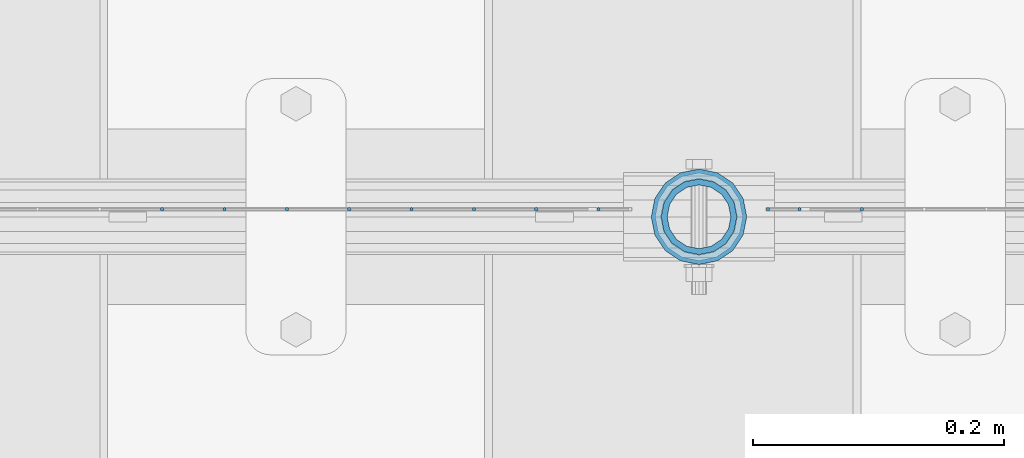
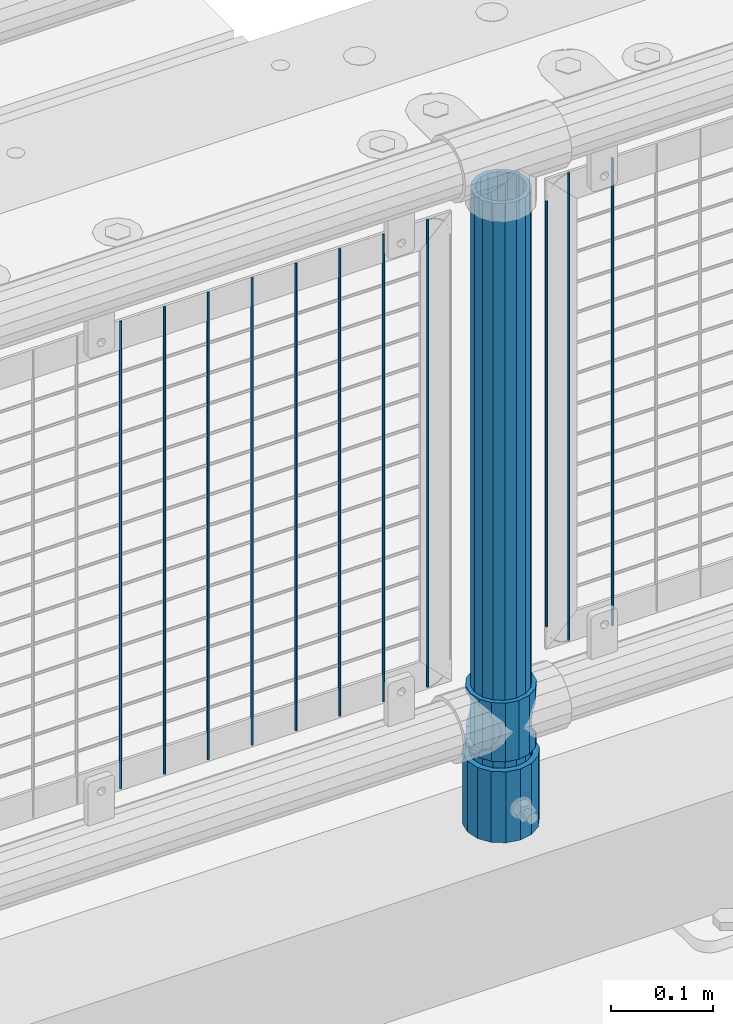
# One storey, part 92 of 247: 14 columns.
"""IFC2X3 building model written with IfcOpenShell, lengths in millimetres."""

from ifc_helpers import new_model, si_unit, frame, origin_with_axes, place, context, subcontext, project, spatial, faceted_brep, material, type_object, element, save


model = new_model("IFC2X3")

# Units and contexts
model_context = context("Model", 3, precision=1e-05, world=origin_with_axes())
body_context = subcontext(model_context, "Body", "Model", "MODEL_VIEW")
ifc_project = project(units=[si_unit("LENGTHUNIT", "METRE", prefix="MILLI"), si_unit("AREAUNIT", "SQUARE_METRE"), si_unit("VOLUMEUNIT", "CUBIC_METRE"), si_unit("MASSUNIT", "GRAM", prefix="KILO"), si_unit("TIMEUNIT", "SECOND"), si_unit("PLANEANGLEUNIT", "RADIAN"), si_unit("SOLIDANGLEUNIT", "STERADIAN"), si_unit("THERMODYNAMICTEMPERATUREUNIT", "DEGREE_CELSIUS"), si_unit("LUMINOUSINTENSITYUNIT", "LUMEN")], contexts=[model_context])

# Site, building, storey
site_placement = place(None, origin_with_axes())
site = spatial("IfcSite", under=ifc_project, at=site_placement, CompositionType="ELEMENT")
building_placement = place(site_placement, origin_with_axes())
building = spatial("IfcBuilding", under=site, at=building_placement, Name="Standard", CompositionType="ELEMENT")
storey_placement = place(building_placement, origin_with_axes())
storey = spatial("IfcBuildingStorey", under=building, at=storey_placement, Name="Undefined", CompositionType="ELEMENT", Elevation=0.0)

# Columns
ifc_material_1 = material()
column_type_1 = type_object("IfcColumnType", PredefinedType="NOTDEFINED")
column_1_placement = place(storey_placement, frame((11821.0, 7664.5, 168.02), z_axis=(0.0, 1.0, 0.0), x_axis=(0.0, 0.0, 1.0)))
element("IfcColumn", 1, at=column_1_placement, inside=storey, type_object=column_type_1, material=ifc_material_1, context=body_context, shape_type="Brep", body=[
    faceted_brep([(0.0, -31.75, 0.0), (0.0, -29.3331751572332, 12.1501989775916), (85.0, -29.3331751572332, 12.1501989775916), (85.0, -31.75, 0.0), (0.0, -22.4506403026735, 22.4506403026726), (85.0, -22.4506403026735, 22.4506403026726), (0.0, -12.1501989775916, 29.3331751572332), (85.0, -12.1501989775916, 29.3331751572332), (0.0, 0.0, 31.75), (85.0, 0.0, 31.75), (0.0, 12.1501989775916, 29.3331751572332), (85.0, 12.1501989775916, 29.3331751572332), (0.0, 22.4506403026735, 22.4506403026726), (85.0, 22.4506403026735, 22.4506403026726), (0.0, 29.3331751572332, 12.1501989775916), (85.0, 29.3331751572332, 12.1501989775916), (0.0, 31.75, 0.0), (85.0, 31.75, 0.0), (0.0, 29.3331751572332, -12.1501989775916), (85.0, 29.3331751572332, -12.1501989775916), (0.0, 22.4506403026735, -22.4506403026726), (85.0, 22.4506403026735, -22.4506403026726), (0.0, 12.1501989775916, -29.3331751572332), (85.0, 12.1501989775916, -29.3331751572332), (0.0, 0.0, -31.75), (85.0, 0.0, -31.75), (0.0, -12.1501989775916, -29.3331751572332), (85.0, -12.1501989775916, -29.3331751572332), (0.0, -22.4506403026735, -22.4506403026726), (85.0, -22.4506403026735, -22.4506403026726), (0.0, -29.3331751572332, -12.1501989775916), (85.0, -29.3331751572332, -12.1501989775916), (0.0, -38.0499999999993, 0.0), (0.0, -35.1536162120537, -14.5611046014919), (85.0, -35.1536162120537, -14.5611046014919), (85.0, -38.0499999999993, 0.0), (0.0, -26.9054130241475, -26.9054130241484), (85.0, -26.9054130241475, -26.9054130241484), (0.0, -14.561104601491, -35.1536162120547), (85.0, -14.561104601491, -35.1536162120547), (0.0, 0.0, -38.0500000000002), (85.0, 0.0, -38.0500000000002), (0.0, 14.561104601491, -35.1536162120547), (85.0, 14.561104601491, -35.1536162120547), (0.0, 26.9054130241475, -26.9054130241484), (85.0, 26.9054130241475, -26.9054130241484), (0.0, 35.1536162120537, -14.5611046014919), (85.0, 35.1536162120537, -14.5611046014919), (0.0, 38.0499999999993, 0.0), (85.0, 38.0499999999993, 0.0), (0.0, 35.1536162120537, 14.5611046014919), (85.0, 35.1536162120537, 14.5611046014919), (0.0, 26.9054130241475, 26.9054130241484), (85.0, 26.9054130241475, 26.9054130241484), (0.0, 14.561104601491, 35.1536162120547), (85.0, 14.561104601491, 35.1536162120547), (0.0, 0.0, 38.0500000000002), (85.0, 0.0, 38.0500000000002), (0.0, -14.561104601491, 35.1536162120547), (85.0, -14.561104601491, 35.1536162120547), (0.0, -26.9054130241475, 26.9054130241484), (85.0, -26.9054130241475, 26.9054130241484), (0.0, -35.1536162120537, 14.5611046014919), (85.0, -35.1536162120537, 14.5611046014919)], [[[0, 1, 2, 3]], [[1, 4, 5, 2]], [[4, 6, 7, 5]], [[6, 8, 9, 7]], [[8, 10, 11, 9]], [[10, 12, 13, 11]], [[12, 14, 15, 13]], [[14, 16, 17, 15]], [[16, 18, 19, 17]], [[18, 20, 21, 19]], [[20, 22, 23, 21]], [[22, 24, 25, 23]], [[24, 26, 27, 25]], [[26, 28, 29, 27]], [[28, 30, 31, 29]], [[30, 0, 3, 31]], [[32, 33, 34, 35]], [[33, 36, 37, 34]], [[36, 38, 39, 37]], [[38, 40, 41, 39]], [[40, 42, 43, 41]], [[42, 44, 45, 43]], [[44, 46, 47, 45]], [[46, 48, 49, 47]], [[48, 50, 51, 49]], [[50, 52, 53, 51]], [[52, 54, 55, 53]], [[54, 56, 57, 55]], [[56, 58, 59, 57]], [[58, 60, 61, 59]], [[60, 62, 63, 61]], [[62, 32, 35, 63]], [[37, 39, 41, 43, 45, 47, 49, 51, 53, 55, 57, 59, 61, 63, 35, 34], [5, 7, 9, 11, 13, 15, 17, 19, 21, 23, 25, 27, 29, 31, 3, 2]], [[62, 60, 58, 56, 54, 52, 50, 48, 46, 44, 42, 40, 38, 36, 33, 32], [30, 28, 26, 24, 22, 20, 18, 16, 14, 12, 10, 8, 6, 4, 1, 0]]]),
])
ifc_material_2 = material(Name="Misc_Undefined")
column_type_2 = type_object("IfcColumnType", PredefinedType="NOTDEFINED")
column_2_placement = place(storey_placement, frame((11821.0, 7664.5, 263.02), z_axis=(-1.0, 0.0, 0.0), x_axis=(0.0, 0.0, 1.0)))
element("IfcColumn", 2, at=column_2_placement, inside=storey, type_object=column_type_2, material=ifc_material_2, context=body_context, shape_type="Brep", body=[
    faceted_brep([(56.6106908090114, 21.4606908090118, -21.4606908090118), (56.6106908090114, 21.4606908090118, -27.1226768591096), (61.9623795176755, 13.4513226476329, -32.4743655677721), (63.1897438117172, 11.6144421722802, -32.839743811719), (63.1897438117172, 11.6144421722802, -28.0397438117179), (46.7644421722801, 28.0397438117179, -11.6144421722802), (46.7644421722801, 28.0397438117179, -20.088203122983), (51.5310424080055, 24.8548033587067, -24.8548033587067), (35.1499999999996, 30.35, 0.0), (35.1499999999996, 30.3500000000004, -16.6306603983649), (23.5355578277192, 28.0397438117179, -11.6144421722802), (23.5355578277192, 28.0397438117179, -20.088203122983), (13.6893091909879, 21.4606908090118, -21.4606908090118), (13.6893091909879, 21.4606908090118, -27.1226768591096), (18.768957591997, 24.8548033587067, -24.8548033587067), (7.11025618828211, 11.6144421722802, -28.0397438117179), (7.11025618828211, 11.6144421722802, -32.839743811719), (8.33762048232387, 13.4513226476329, -32.4743655677721), (4.79999999999961, 0.0, -30.3500000000004), (4.79999999999961, 0.0, -35.1499999999996), (7.11025618828211, -11.6144421722802, -28.0397438117179), (7.11025618828211, -11.6144421722802, -32.839743811719), (13.6893091909879, -21.4606908090118, -21.4606908090118), (13.6893091909879, -21.4606908090118, -27.1226768591077), (8.33762048232325, -13.4513226476329, -32.4743655677721), (23.5355578277191, -28.0397438117179, -11.6144421722802), (23.5355578277191, -28.0397438117179, -20.0882031229885), (18.768957591997, -24.8548033587067, -24.8548033587067), (35.1499999999996, -30.35, 0.0), (35.1499999999996, -30.3500000000004, -16.6306603983739), (46.7644421722801, -28.0397438117179, -11.6144421722802), (46.7644421722801, -28.0397438117179, -20.0882031229885), (56.6106908090114, -21.4606908090118, -21.4606908090118), (56.6106908090114, -21.4606908090118, -27.1226768591077), (51.5310424080038, -24.8548033587067, -24.8548033587067), (63.1897438117172, -11.6144421722802, -28.0397438117179), (63.1897438117172, -11.6144421722802, -32.839743811719), (61.9623795176754, -13.4513226476329, -32.4743655677721), (65.4999999999997, 0.0, -30.3500000000004), (65.4999999999997, 0.0, -35.1499999999996), (0.0, -28.0397438117179, -11.6144421722802), (0.0, -30.3500000000004, 0.0), (0.0, -21.4606908090118, -21.4606908090118), (0.0, -11.6144421722802, -28.0397438117179), (0.0, 0.0, -30.3500000000004), (0.0, 11.6144421722802, -28.0397438117179), (0.0, 21.4606908090118, -21.4606908090118), (0.0, 28.0397438117179, -11.6144421722802), (0.0, 30.3500000000004, 0.0), (0.0, 28.0397438117179, 11.6144421722802), (23.5355578277192, 28.0397438117179, 11.6144421722806), (0.0, 21.4606908090118, 21.4606908090118), (13.6893091909879, 21.4606908090118, 21.4606908090118), (0.0, 11.6144421722802, 28.0397438117179), (7.11025618828211, 11.6144421722802, 28.0397438117175), (0.0, 0.0, 30.3500000000004), (4.79999999999961, 0.0, 30.3499999999999), (0.0, -11.6144421722802, 28.0397438117179), (7.11025618828205, -11.6144421722802, 28.0397438117175), (0.0, -21.4606908090118, 21.4606908090118), (13.6893091909879, -21.4606908090118, 21.4606908090118), (0.0, -28.0397438117179, 11.6144421722802), (23.5355578277191, -28.0397438117179, 11.6144421722806), (0.0, -32.4743655677721, 13.4513226476338), (0.0, -35.1499999999996, 0.0), (70.2999999999993, -35.1499999999996, 0.0), (70.2999999999993, -32.4743655677721, 13.4513226476338), (0.0, 13.4513226476329, -32.4743655677721), (0.0, 24.8548033587067, -24.8548033587067), (0.0, 0.0, -35.1499999999996), (0.0, -13.4513226476329, -32.4743655677721), (0.0, -24.8548033587067, -24.8548033587067), (0.0, -24.8548033587067, 24.8548033587067), (0.0, -13.4513226476329, 32.4743655677721), (0.0, 0.0, 35.1499999999996), (0.0, 13.4513226476329, 32.4743655677721), (0.0, 24.8548033587067, 24.8548033587067), (0.0, 32.4743655677721, 13.4513226476338), (0.0, 35.1499999999996, 0.0), (0.0, 32.4743655677721, -13.4513226476338), (0.0, -32.4743655677721, -13.4513226476338), (70.2999999999993, 32.4743655677721, 13.4513226476338), (70.2999999999993, 35.1499999999996, 0.0), (70.2999999999993, 32.4743655677721, -13.4513226476338), (70.2999999999993, 24.8548033587067, -24.8548033587067), (70.2999999999993, 13.4513226476329, -32.4743655677721), (70.2999999999993, 0.0, -35.1499999999996), (70.2999999999993, -13.4513226476329, -32.4743655677721), (70.2999999999993, -24.8548033587067, -24.8548033587067), (70.2999999999993, -32.4743655677721, -13.4513226476338), (70.2999999999993, 28.0397438117179, 11.6144421722802), (70.2999999999993, 21.4606908090118, 21.4606908090118), (56.6106908090114, 21.4606908090118, 21.4606908090118), (46.7644421722801, 28.0397438117179, 11.6144421722806), (70.2999999999993, 11.6144421722802, 28.0397438117179), (63.1897438117172, 11.6144421722802, 28.0397438117175), (70.2999999999993, 0.0, 30.3500000000004), (65.4999999999997, 0.0, 30.3499999999999), (70.2999999999993, -11.6144421722802, 28.0397438117179), (63.1897438117172, -11.6144421722802, 28.0397438117175), (70.2999999999993, -21.4606908090118, 21.4606908090118), (56.6106908090114, -21.4606908090118, 21.4606908090118), (70.2999999999993, -28.0397438117179, 11.6144421722802), (46.7644421722801, -28.0397438117179, 11.6144421722806), (70.2999999999993, -11.6144421722802, -28.0397438117179), (70.2999999999993, 0.0, -30.3500000000004), (70.2999999999993, -21.4606908090118, -21.4606908090118), (70.2999999999993, -28.0397438117179, -11.6144421722802), (70.2999999999993, -30.3500000000004, 0.0), (70.2999999999993, 24.8548033587067, 24.8548033587067), (70.2999999999993, 13.4513226476329, 32.4743655677721), (70.2999999999993, 0.0, 35.1499999999996), (70.2999999999993, -13.4513226476329, 32.4743655677721), (70.2999999999993, -24.8548033587067, 24.8548033587067), (70.2999999999993, 30.3500000000004, 0.0), (70.2999999999993, 28.0397438117179, -11.6144421722802), (70.2999999999993, 21.4606908090118, -21.4606908090118), (70.2999999999993, 11.6144421722802, -28.0397438117179), (61.9623795176755, 13.4513226476329, 32.4743655677717), (51.5310424080043, 24.8548033587067, 24.8548033587072), (56.6106908090114, 21.4606908090118, 27.1226768591082), (65.4999999999997, 0.0, 35.1500000000001), (63.1897438117172, 11.6144421722802, 32.8397438117177), (63.1897438117172, -11.6144421722802, 32.8397438117177), (61.962379517675, -13.4513226476329, 32.4743655677717), (56.6106908090114, -21.4606908090118, 27.1226768591068), (51.5310424080026, -24.8548033587067, 24.8548033587072), (18.7689575919956, -24.8548033587067, 24.8548033587072), (46.7644421722801, -28.0397438117179, 20.088203122983), (35.1499999999996, -30.3500000000004, 16.6306603983649), (23.5355578277191, -28.0397438117179, 20.088203122983), (8.33762048232268, -13.4513226476329, 32.4743655677717), (13.6893091909879, -21.4606908090118, 27.1226768591068), (4.79999999999961, 0.0, 35.1500000000001), (7.11025618828205, -11.6144421722802, 32.8397438117177), (7.11025618828211, 11.6144421722802, 32.8397438117177), (8.33762048232427, 13.4513226476329, 32.4743655677717), (13.6893091909879, 21.4606908090118, 27.1226768591082), (18.7689575919966, 24.8548033587067, 24.8548033587072), (23.5355578277192, 28.0397438117179, 20.0882031229844), (35.1499999999996, 30.3500000000004, 16.6306603983667), (46.7644421722801, 28.0397438117179, 20.0882031229844)], [[[0, 1, 2, 3, 4]], [[5, 6, 7, 1, 0]], [[8, 9, 6, 5]], [[10, 11, 9, 8]], [[12, 13, 14, 11, 10]], [[15, 16, 17, 13, 12]], [[18, 19, 16, 15]], [[20, 21, 19, 18]], [[22, 23, 24, 21, 20]], [[25, 26, 27, 23, 22]], [[28, 29, 26, 25]], [[30, 31, 29, 28]], [[32, 33, 34, 31, 30]], [[35, 36, 37, 33, 32]], [[38, 39, 36, 35]], [[4, 3, 39, 38]], [[40, 41, 28, 25]], [[42, 40, 25, 22]], [[43, 42, 22, 20]], [[44, 43, 20, 18]], [[45, 44, 18, 15]], [[46, 45, 15, 12]], [[47, 46, 12, 10]], [[48, 47, 10, 8]], [[49, 48, 8, 50]], [[51, 49, 50, 52]], [[53, 51, 52, 54]], [[55, 53, 54, 56]], [[57, 55, 56, 58]], [[59, 57, 58, 60]], [[61, 59, 60, 62]], [[41, 61, 62, 28]], [[63, 64, 65, 66]], [[17, 67, 68, 14, 13]], [[19, 69, 67, 17, 16]], [[70, 69, 19, 21, 24]], [[71, 70, 24, 23, 27]], [[63, 72, 73, 74, 75, 76, 77, 78, 79, 68, 67, 69, 70, 71, 80, 64], [40, 42, 43, 44, 45, 46, 47, 48, 49, 51, 53, 55, 57, 59, 61, 41]], [[78, 77, 81, 82]], [[79, 78, 82, 83]], [[14, 68, 79, 83, 84, 7, 6, 9, 11]], [[84, 85, 2, 1, 7]], [[85, 86, 39, 3, 2]], [[37, 87, 88, 34, 33]], [[39, 86, 87, 37, 36]], [[34, 88, 89, 80, 71, 27, 26, 29, 31]], [[64, 80, 89, 65]], [[90, 91, 92, 93]], [[91, 94, 95, 92]], [[94, 96, 97, 95]], [[96, 98, 99, 97]], [[98, 100, 101, 99]], [[100, 102, 103, 101]], [[104, 105, 38, 35]], [[106, 104, 35, 32]], [[107, 106, 32, 30]], [[108, 107, 30, 28]], [[102, 108, 28, 103]], [[88, 87, 86, 85, 84, 83, 82, 81, 109, 110, 111, 112, 113, 66, 65, 89], [100, 98, 96, 94, 91, 90, 114, 115, 116, 117, 105, 104, 106, 107, 108, 102]], [[118, 110, 109, 119, 120]], [[121, 111, 110, 118, 122]], [[112, 111, 121, 123, 124]], [[113, 112, 124, 125, 126]], [[127, 72, 63, 66, 113, 126, 128, 129, 130]], [[131, 73, 72, 127, 132]], [[133, 74, 73, 131, 134]], [[75, 74, 133, 135, 136]], [[76, 75, 136, 137, 138]], [[119, 109, 81, 77, 76, 138, 139, 140, 141]], [[92, 120, 119, 141, 93]], [[95, 122, 118, 120, 92]], [[97, 121, 122, 95]], [[99, 123, 121, 97]], [[101, 125, 124, 123, 99]], [[103, 128, 126, 125, 101]], [[28, 129, 128, 103]], [[62, 130, 129, 28]], [[60, 132, 127, 130, 62]], [[58, 134, 131, 132, 60]], [[56, 133, 134, 58]], [[54, 135, 133, 56]], [[52, 137, 136, 135, 54]], [[50, 139, 138, 137, 52]], [[8, 140, 139, 50]], [[93, 141, 140, 8]], [[114, 90, 93, 8]], [[115, 114, 8, 5]], [[116, 115, 5, 0]], [[117, 116, 0, 4]], [[105, 117, 4, 38]]]),
])
column_type_3 = type_object("IfcColumnType", PredefinedType="NOTDEFINED")
column_3_placement = place(storey_placement, frame((11821.0, 7664.5, 168.02), z_axis=(-1.0, 0.0, 0.0), x_axis=(0.0, 0.0, 1.0)))
element("IfcColumn", 3, at=column_3_placement, inside=storey, type_object=column_type_3, material=ifc_material_1, context=body_context, shape_type="Brep", body=[
    faceted_brep([(0.0, -25.3500000000004, 0.0), (0.0, -23.4203461491616, 9.70102501045585), (760.0, -23.4203461491616, 9.70102501045585), (760.0, -25.3500000000004, 0.0), (0.0, -17.9251569030794, 17.9251569030785), (760.0, -17.9251569030794, 17.9251569030785), (0.0, -9.70102501045494, 23.4203461491616), (760.0, -9.70102501045494, 23.4203461491616), (0.0, 0.0, 25.3500000000004), (760.0, 0.0, 25.3500000000004), (0.0, 9.70102501045494, 23.4203461491616), (760.0, 9.70102501045494, 23.4203461491616), (0.0, 17.9251569030794, 17.9251569030785), (760.0, 17.9251569030794, 17.9251569030785), (0.0, 23.4203461491616, 9.70102501045585), (760.0, 23.4203461491616, 9.70102501045585), (0.0, 25.3500000000004, 0.0), (760.0, 25.3500000000004, 0.0), (0.0, 23.4203461491616, -9.70102501045585), (760.0, 23.4203461491616, -9.70102501045585), (0.0, 17.9251569030794, -17.9251569030785), (760.0, 17.9251569030794, -17.9251569030785), (0.0, 9.70102501045494, -23.4203461491616), (760.0, 9.70102501045494, -23.4203461491616), (0.0, 0.0, -25.3500000000004), (760.0, 0.0, -25.3500000000004), (0.0, -9.70102501045494, -23.4203461491616), (760.0, -9.70102501045494, -23.4203461491616), (0.0, -17.9251569030794, -17.9251569030785), (760.0, -17.9251569030794, -17.9251569030785), (0.0, -23.4203461491616, -9.70102501045585), (760.0, -23.4203461491616, -9.70102501045585), (0.0, -30.1499999999996, 0.0), (0.0, -27.8549679052148, -11.5379054858076), (760.0, -27.8549679052148, -11.5379054858076), (760.0, -30.1499999999996, 0.0), (0.0, -21.3192694527743, -21.3192694527752), (760.0, -21.3192694527743, -21.3192694527752), (0.0, -11.5379054858076, -27.8549679052157), (760.0, -11.5379054858076, -27.8549679052157), (0.0, 0.0, -30.1499999999996), (760.0, 0.0, -30.1499999999996), (0.0, 11.5379054858076, -27.8549679052157), (760.0, 11.5379054858076, -27.8549679052157), (0.0, 21.3192694527743, -21.3192694527752), (760.0, 21.3192694527743, -21.3192694527752), (0.0, 27.8549679052157, -11.5379054858076), (760.0, 27.8549679052157, -11.5379054858076), (0.0, 30.1499999999996, 0.0), (760.0, 30.1499999999996, 0.0), (0.0, 27.8549679052157, 11.5379054858076), (760.0, 27.8549679052157, 11.5379054858076), (0.0, 21.3192694527743, 21.3192694527752), (760.0, 21.3192694527743, 21.3192694527752), (0.0, 11.5379054858076, 27.8549679052157), (760.0, 11.5379054858076, 27.8549679052157), (0.0, 0.0, 30.1499999999996), (760.0, 0.0, 30.1499999999996), (0.0, -11.5379054858076, 27.8549679052157), (760.0, -11.5379054858076, 27.8549679052157), (0.0, -21.3192694527743, 21.3192694527752), (760.0, -21.3192694527743, 21.3192694527752), (0.0, -27.8549679052157, 11.5379054858076), (760.0, -27.8549679052157, 11.5379054858076)], [[[0, 1, 2, 3]], [[1, 4, 5, 2]], [[4, 6, 7, 5]], [[6, 8, 9, 7]], [[8, 10, 11, 9]], [[10, 12, 13, 11]], [[12, 14, 15, 13]], [[14, 16, 17, 15]], [[16, 18, 19, 17]], [[18, 20, 21, 19]], [[20, 22, 23, 21]], [[22, 24, 25, 23]], [[24, 26, 27, 25]], [[26, 28, 29, 27]], [[28, 30, 31, 29]], [[30, 0, 3, 31]], [[32, 33, 34, 35]], [[33, 36, 37, 34]], [[36, 38, 39, 37]], [[38, 40, 41, 39]], [[40, 42, 43, 41]], [[42, 44, 45, 43]], [[44, 46, 47, 45]], [[46, 48, 49, 47]], [[48, 50, 51, 49]], [[50, 52, 53, 51]], [[52, 54, 55, 53]], [[54, 56, 57, 55]], [[56, 58, 59, 57]], [[58, 60, 61, 59]], [[60, 62, 63, 61]], [[62, 32, 35, 63]], [[37, 39, 41, 43, 45, 47, 49, 51, 53, 55, 57, 59, 61, 63, 35, 34], [5, 7, 9, 11, 13, 15, 17, 19, 21, 23, 25, 27, 29, 31, 3, 2]], [[62, 60, 58, 56, 54, 52, 50, 48, 46, 44, 42, 40, 38, 36, 33, 32], [30, 28, 26, 24, 22, 20, 18, 16, 14, 12, 10, 8, 6, 4, 1, 0]]]),
])
column_type_4 = type_object("IfcColumnType", Name="D3", PredefinedType="NOTDEFINED")
column_4_placement = place(storey_placement, frame((11950.6551724138, 7670.50000000001, 353.020000000005), z_axis=(-0.999999999962839, 0.0, 8.62099999968473e-06), x_axis=(8.62099999949798e-06, 0.0, 0.999999999962839)))
element("IfcColumn", 4, at=column_4_placement, inside=storey, type_object=column_type_4, material=ifc_material_2, ObjectType="D3", context=body_context, shape_type="Brep", body=[
    faceted_brep([(1.81898940354586e-12, -1.5, -5.6843418860808e-14), (0.0, -0.75, -1.29903810567703), (560.0, -0.75, -1.29903810567703), (560.0, -1.5, 0.0), (0.0, 0.75, -1.29903810567703), (560.0, 0.75, -1.29903810567703), (1.81898940354586e-12, 1.5, -5.6843418860808e-14), (560.0, 1.5, 0.0), (0.0, 0.75, 1.29903810567703), (560.0, 0.75, 1.29903810567703), (0.0, -0.75, 1.29903810567703), (560.0, -0.75, 1.29903810567703)], [[[0, 1, 2, 3]], [[1, 4, 5, 2]], [[4, 6, 7, 5]], [[6, 8, 9, 7]], [[8, 10, 11, 9]], [[10, 0, 3, 11]], [[5, 7, 9, 11, 3, 2]], [[10, 8, 6, 4, 1, 0]]]),
])
column_5_placement = place(storey_placement, frame((11876.0, 7670.50000000001, 378.020000000005), z_axis=(-1.0, 0.0, 0.0), x_axis=(0.0, 0.0, 1.0)))
element("IfcColumn", 5, at=column_5_placement, inside=storey, type_object=column_type_4, material=ifc_material_2, ObjectType="D3", context=body_context, shape_type="Brep", body=[
    faceted_brep([(1.81898940354586e-12, -1.5, -5.6843418860808e-14), (0.0, -0.75, -1.29903810567703), (510.0, -0.75, -1.29903810567703), (510.0, -1.5, 0.0), (0.0, 0.75, -1.29903810567703), (510.0, 0.75, -1.29903810567703), (1.81898940354586e-12, 1.5, -5.6843418860808e-14), (510.0, 1.5, 0.0), (0.0, 0.75, 1.29903810567703), (510.0, 0.75, 1.29903810567703), (0.0, -0.75, 1.29903810567703), (510.0, -0.75, 1.29903810567703)], [[[0, 1, 2, 3]], [[1, 4, 5, 2]], [[4, 6, 7, 5]], [[6, 8, 9, 7]], [[8, 10, 11, 9]], [[10, 0, 3, 11]], [[5, 7, 9, 11, 3, 2]], [[10, 8, 6, 4, 1, 0]]]),
])
for number, where, z_axis, x_axis in (
    (6, (11901.0, 7670.50000000001, 353.020000000005), (-1.0, 0.0, 0.0), (0.0, 0.0, 1.0)),
    (7, (11740.995, 7670.50000000001, 353.020000000004), (-1.0, 0.0, 0.0), (0.0, 0.0, 1.0)),
    (8, (11691.34, 7670.50000000001, 353.020000000004), (-1.0, 0.0, 0.0), (0.0, 0.0, 1.0)),
    (9, (11641.685, 7670.50000000001, 353.020000000004), (-1.0, 0.0, 0.0), (0.0, 0.0, 1.0)),
    (10, (11592.03, 7670.50000000001, 353.020000000004), (-1.0, 0.0, 0.0), (0.0, 0.0, 1.0)),
    (11, (11542.375, 7670.50000000001, 353.020000000004), (-1.0, 0.0, 0.0), (0.0, 0.0, 1.0)),
    (12, (11492.72, 7670.50000000001, 353.020000000004), (-1.0, 0.0, 0.0), (0.0, 0.0, 1.0)),
    (13, (11443.065, 7670.50000000001, 353.020000000004), (-1.0, 0.0, 0.0), (0.0, 0.0, 1.0)),
    (14, (11393.41, 7670.50000000001, 353.020000000004), (-1.0, 0.0, 0.0), (0.0, 0.0, 1.0)),
):
    element("IfcColumn", number, at=place(storey_placement, frame(where, z_axis=z_axis, x_axis=x_axis)), inside=storey, type_object=column_type_4, material=ifc_material_2, ObjectType="D3", context=body_context, shape_type="Brep", body=[
        faceted_brep([(1.81898940354586e-12, -1.5, -5.6843418860808e-14), (0.0, -0.75, -1.29903810567703), (560.0, -0.75, -1.29903810567703), (560.0, -1.5, 0.0), (0.0, 0.75, -1.29903810567703), (560.0, 0.75, -1.29903810567703), (1.81898940354586e-12, 1.5, -5.6843418860808e-14), (560.0, 1.5, 0.0), (0.0, 0.75, 1.29903810567703), (560.0, 0.75, 1.29903810567703), (0.0, -0.75, 1.29903810567703), (560.0, -0.75, 1.29903810567703)], [[[0, 1, 2, 3]], [[1, 4, 5, 2]], [[4, 6, 7, 5]], [[6, 8, 9, 7]], [[8, 10, 11, 9]], [[10, 0, 3, 11]], [[5, 7, 9, 11, 3, 2]], [[10, 8, 6, 4, 1, 0]]]),
    ])

save(model, "model.ifc")
